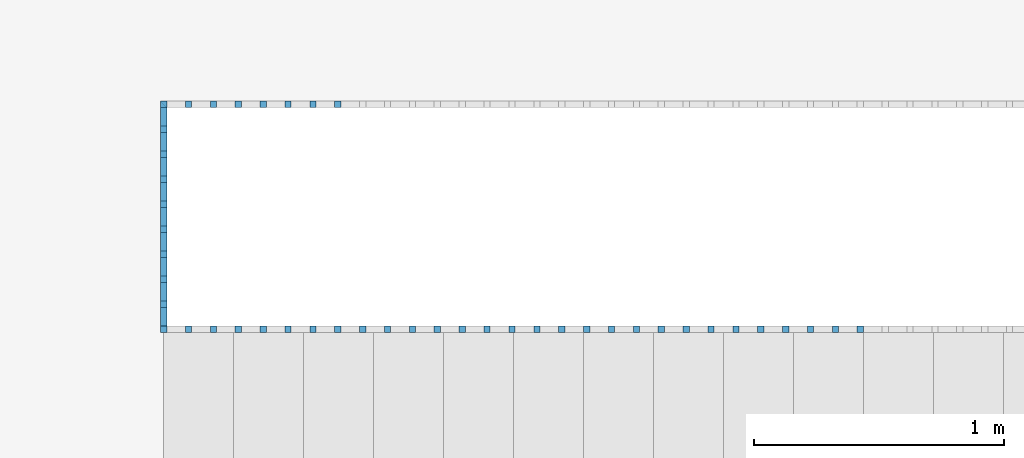
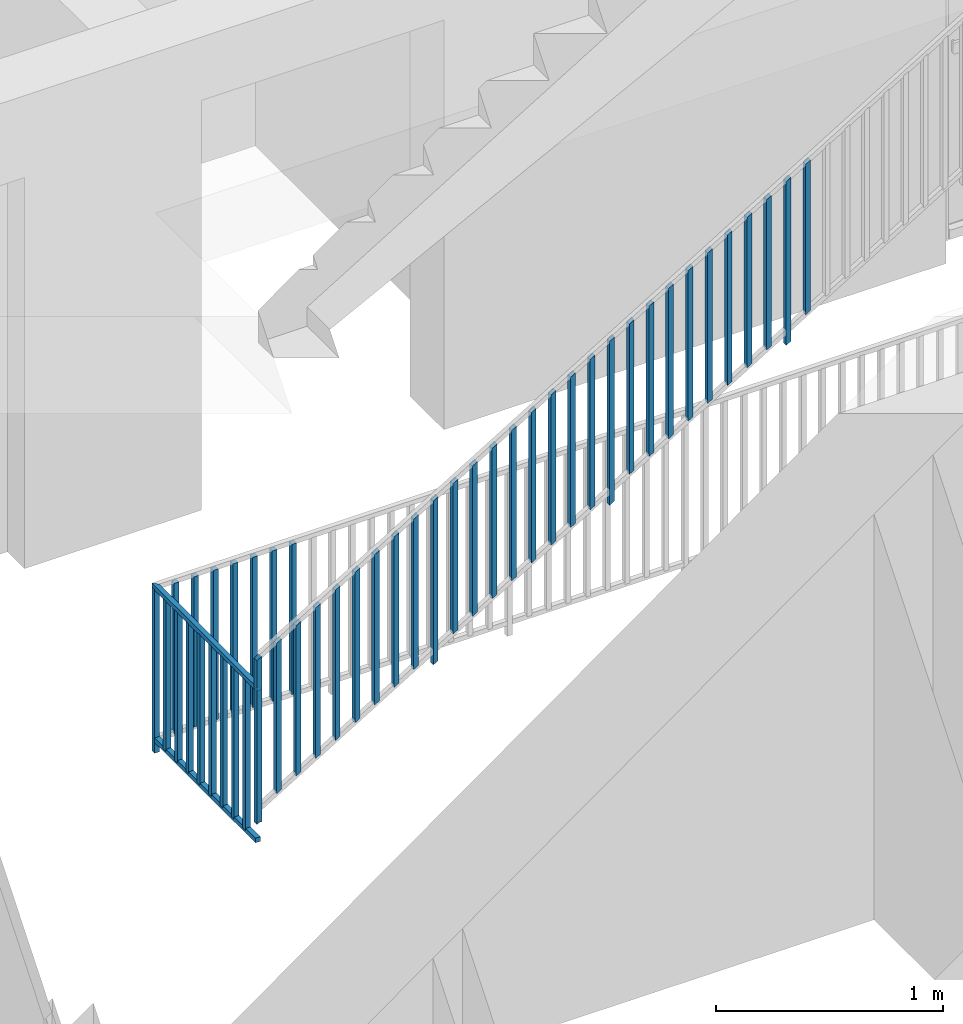
# One storey, part 33 of 48: 48 building element parts, 2 elements without a shape of their own.
"""IFC4 building model written with IfcOpenShell, lengths in metres."""

from ifc_helpers import new_model, entity, si_unit, converted_unit, derived_unit, direction, frame, origin_with_axes, place, context, subcontext, project, spatial, polygons, material, type_object, element, aggregate, save


model = new_model("IFC4")

# Units and contexts
model_context = context("Model", 3, precision=1e-05, world=origin_with_axes(), true_north=direction((0.0, 1.0)))
body_context = subcontext(model_context, "Body", "Model", "MODEL_VIEW")
ifc_project = project(units=[si_unit("LENGTHUNIT", "METRE"), si_unit("AREAUNIT", "SQUARE_METRE"), si_unit("VOLUMEUNIT", "CUBIC_METRE"), converted_unit("PLANEANGLEUNIT", "DEGREE", entity("IfcPlaneAngleMeasure", 0.0174532925199), si_unit("PLANEANGLEUNIT", "RADIAN"), dimensions=[0, 0, 0, 0, 0, 0, 0]), converted_unit("TIMEUNIT", "Year", entity("IfcTimeMeasure", 31556926.0), si_unit("TIMEUNIT", "SECOND"), dimensions=[0, 0, 1, 0, 0, 0, 0]), si_unit("MASSUNIT", "GRAM", prefix="KILO"), si_unit("THERMODYNAMICTEMPERATUREUNIT", "DEGREE_CELSIUS"), si_unit("LUMINOUSINTENSITYUNIT", "LUMEN"), si_unit("ENERGYUNIT", "JOULE", prefix="MEGA"), derived_unit("THERMALCONDUCTANCEUNIT", [(si_unit("POWERUNIT", "WATT"), 1), (si_unit("LENGTHUNIT", "METRE"), -1), (si_unit("THERMODYNAMICTEMPERATUREUNIT", "KELVIN"), -1)]), derived_unit("SPECIFICHEATCAPACITYUNIT", [(si_unit("ENERGYUNIT", "JOULE"), 1), (si_unit("MASSUNIT", "GRAM", prefix="KILO"), -1), (si_unit("THERMODYNAMICTEMPERATUREUNIT", "KELVIN"), -1)]), derived_unit("MASSDENSITYUNIT", [(si_unit("MASSUNIT", "GRAM", prefix="KILO"), 1), (si_unit("VOLUMEUNIT", "CUBIC_METRE"), -1)])], contexts=[model_context])

# Site, building, storey, space
site_placement = place(None, origin_with_axes())
site = spatial("IfcSite", under=ifc_project, at=site_placement, CompositionType="ELEMENT")
building_placement = place(site_placement, origin_with_axes())
building = spatial("IfcBuilding", under=site, at=building_placement, CompositionType="ELEMENT")
storey_placement = place(building_placement, frame((0.0, 0.0, 3.4), z_axis=(0.0, 0.0, 1.0), x_axis=(1.0, 0.0, 0.0)))
storey = spatial("IfcBuildingStorey", under=building, at=storey_placement, Name="1. Geschoss", CompositionType="ELEMENT", Elevation=3.4)
space_placement = place(storey_placement, frame((-3.4421993804, -2.52881223104, 0.0), z_axis=(0.0, 0.0, 1.0), x_axis=(1.0, 0.0, 0.0)))
space = spatial("IfcSpace", under=storey, at=space_placement, CompositionType="ELEMENT", PredefinedType="INTERNAL")

# Railing, building element parts
railing_type = type_object("IfcRailingType", PredefinedType="NOTDEFINED")
railing_1_placement = place(space_placement, frame((0.0, 1.5, 0.17), z_axis=(0.0, 0.0, 1.0), x_axis=(1.0, 0.0, 0.0)))
railing_1 = element("IfcRailing", 1, at=railing_1_placement, inside=space, type_object=railing_type, PredefinedType="NOTDEFINED")
ifc_material = material()
building_element_part_1_placement = place(railing_1_placement, origin_with_axes())
building_element_part_1 = element("IfcBuildingElementPart", 2, at=building_element_part_1_placement, material=ifc_material, PredefinedType="NOTDEFINED", context=body_context, shape_type="Tessellation", body=[
    polygons([(0.0125, -0.0125, 0.00758928571429), (0.0125, 0.0125, 0.00758928571429), (0.0125, 0.0125, 0.887589285714), (0.0125, -0.0125, 0.887589285714), (-0.0125, -0.0125, -0.00758928571429), (-0.0125, 0.0125, -0.00758928571429), (-0.0125, 0.0125, 0.872410714286), (-0.0125, -0.0125, 0.872410714286)], [[[1, 2, 3, 4]], [[1, 5, 6, 2]], [[2, 6, 7, 3]], [[4, 3, 7, 8]], [[5, 1, 4, 8]], [[6, 5, 8, 7]]], closed=True),
])
building_element_part_2_placement = place(railing_1_placement, origin_with_axes())
building_element_part_2 = element("IfcBuildingElementPart", 3, at=building_element_part_2_placement, material=ifc_material, PredefinedType="NOTDEFINED", context=body_context, shape_type="Tessellation", body=[
    polygons([(0.112055555556, -0.0125, 0.138033730159), (0.112055555556, 0.0125, 0.138033730159), (0.112055555556, 0.0125, 0.945533730159), (0.112055555556, -0.0125, 0.945533730159), (0.0870555555556, -0.0125, 0.12285515873), (0.0870555555556, 0.0125, 0.12285515873), (0.0870555555556, 0.0125, 0.93035515873), (0.0870555555556, -0.0125, 0.93035515873)], [[[1, 2, 3, 4]], [[1, 5, 6, 2]], [[2, 6, 7, 3]], [[4, 3, 7, 8]], [[5, 1, 4, 8]], [[6, 5, 8, 7]]], closed=True),
])
building_element_part_3_placement = place(railing_1_placement, origin_with_axes())
building_element_part_3 = element("IfcBuildingElementPart", 4, at=building_element_part_3_placement, material=ifc_material, PredefinedType="NOTDEFINED", context=body_context, shape_type="Tessellation", body=[
    polygons([(0.211611111111, -0.0125, 0.198478174603), (0.211611111111, 0.0125, 0.198478174603), (0.211611111111, 0.0125, 1.0059781746), (0.211611111111, -0.0125, 1.0059781746), (0.186611111111, -0.0125, 0.183299603175), (0.186611111111, 0.0125, 0.183299603175), (0.186611111111, 0.0125, 0.990799603175), (0.186611111111, -0.0125, 0.990799603175)], [[[1, 2, 3, 4]], [[1, 5, 6, 2]], [[2, 6, 7, 3]], [[4, 3, 7, 8]], [[5, 1, 4, 8]], [[6, 5, 8, 7]]], closed=True),
])
building_element_part_4_placement = place(railing_1_placement, origin_with_axes())
building_element_part_4 = element("IfcBuildingElementPart", 5, at=building_element_part_4_placement, material=ifc_material, PredefinedType="NOTDEFINED", context=body_context, shape_type="Tessellation", body=[
    polygons([(0.311166666667, -0.0125, 0.258922619048), (0.311166666667, 0.0125, 0.258922619048), (0.311166666667, 0.0125, 1.06642261905), (0.311166666667, -0.0125, 1.06642261905), (0.286166666667, -0.0125, 0.243744047619), (0.286166666667, 0.0125, 0.243744047619), (0.286166666667, 0.0125, 1.05124404762), (0.286166666667, -0.0125, 1.05124404762)], [[[1, 2, 3, 4]], [[1, 5, 6, 2]], [[2, 6, 7, 3]], [[4, 3, 7, 8]], [[5, 1, 4, 8]], [[6, 5, 8, 7]]], closed=True),
])
building_element_part_5_placement = place(railing_1_placement, origin_with_axes())
building_element_part_5 = element("IfcBuildingElementPart", 6, at=building_element_part_5_placement, material=ifc_material, PredefinedType="NOTDEFINED", context=body_context, shape_type="Tessellation", body=[
    polygons([(0.410722222222, -0.0125, 0.319367063492), (0.410722222222, 0.0125, 0.319367063492), (0.410722222222, 0.0125, 1.12686706349), (0.410722222222, -0.0125, 1.12686706349), (0.385722222222, -0.0125, 0.304188492063), (0.385722222222, 0.0125, 0.304188492063), (0.385722222222, 0.0125, 1.11168849206), (0.385722222222, -0.0125, 1.11168849206)], [[[1, 2, 3, 4]], [[1, 5, 6, 2]], [[2, 6, 7, 3]], [[4, 3, 7, 8]], [[5, 1, 4, 8]], [[6, 5, 8, 7]]], closed=True),
])
building_element_part_6_placement = place(railing_1_placement, origin_with_axes())
building_element_part_6 = element("IfcBuildingElementPart", 7, at=building_element_part_6_placement, material=ifc_material, PredefinedType="NOTDEFINED", context=body_context, shape_type="Tessellation", body=[
    polygons([(0.510277777778, -0.0125, 0.379811507937), (0.510277777778, 0.0125, 0.379811507937), (0.510277777778, 0.0125, 1.18731150794), (0.510277777778, -0.0125, 1.18731150794), (0.485277777778, -0.0125, 0.364632936508), (0.485277777778, 0.0125, 0.364632936508), (0.485277777778, 0.0125, 1.17213293651), (0.485277777778, -0.0125, 1.17213293651)], [[[1, 2, 3, 4]], [[1, 5, 6, 2]], [[2, 6, 7, 3]], [[4, 3, 7, 8]], [[5, 1, 4, 8]], [[6, 5, 8, 7]]], closed=True),
])
building_element_part_7_placement = place(railing_1_placement, origin_with_axes())
building_element_part_7 = element("IfcBuildingElementPart", 8, at=building_element_part_7_placement, material=ifc_material, PredefinedType="NOTDEFINED", context=body_context, shape_type="Tessellation", body=[
    polygons([(0.609833333333, -0.0125, 0.440255952381), (0.609833333333, 0.0125, 0.440255952381), (0.609833333333, 0.0125, 1.24775595238), (0.609833333333, -0.0125, 1.24775595238), (0.584833333333, -0.0125, 0.425077380952), (0.584833333333, 0.0125, 0.425077380952), (0.584833333333, 0.0125, 1.23257738095), (0.584833333333, -0.0125, 1.23257738095)], [[[1, 2, 3, 4]], [[1, 5, 6, 2]], [[2, 6, 7, 3]], [[4, 3, 7, 8]], [[5, 1, 4, 8]], [[6, 5, 8, 7]]], closed=True),
])
building_element_part_8_placement = place(railing_1_placement, origin_with_axes())
building_element_part_8 = element("IfcBuildingElementPart", 9, at=building_element_part_8_placement, material=ifc_material, PredefinedType="NOTDEFINED", context=body_context, shape_type="Tessellation", body=[
    polygons([(0.709388888889, -0.0125, 0.500700396825), (0.709388888889, 0.0125, 0.500700396825), (0.709388888889, 0.0125, 1.30820039683), (0.709388888889, -0.0125, 1.30820039683), (0.684388888889, -0.0125, 0.485521825397), (0.684388888889, 0.0125, 0.485521825397), (0.684388888889, 0.0125, 1.2930218254), (0.684388888889, -0.0125, 1.2930218254)], [[[1, 2, 3, 4]], [[1, 5, 6, 2]], [[2, 6, 7, 3]], [[4, 3, 7, 8]], [[5, 1, 4, 8]], [[6, 5, 8, 7]]], closed=True),
])
building_element_part_9_placement = place(railing_1_placement, origin_with_axes())
building_element_part_9 = element("IfcBuildingElementPart", 10, at=building_element_part_9_placement, material=ifc_material, PredefinedType="NOTDEFINED", context=body_context, shape_type="Tessellation", body=[
    polygons([(0.808944444444, -0.0125, 0.56114484127), (0.808944444444, 0.0125, 0.56114484127), (0.808944444444, 0.0125, 1.36864484127), (0.808944444444, -0.0125, 1.36864484127), (0.783944444444, -0.0125, 0.545966269841), (0.783944444444, 0.0125, 0.545966269841), (0.783944444444, 0.0125, 1.35346626984), (0.783944444444, -0.0125, 1.35346626984)], [[[1, 2, 3, 4]], [[1, 5, 6, 2]], [[2, 6, 7, 3]], [[4, 3, 7, 8]], [[5, 1, 4, 8]], [[6, 5, 8, 7]]], closed=True),
])
building_element_part_10_placement = place(railing_1_placement, origin_with_axes())
building_element_part_10 = element("IfcBuildingElementPart", 11, at=building_element_part_10_placement, material=ifc_material, PredefinedType="NOTDEFINED", context=body_context, shape_type="Tessellation", body=[
    polygons([(0.9085, -0.0125, 0.551589285714), (0.9085, 0.0125, 0.551589285714), (0.9085, 0.0125, 1.43158928571), (0.9085, -0.0125, 1.43158928571), (0.8835, -0.0125, 0.536410714286), (0.8835, 0.0125, 0.536410714286), (0.8835, 0.0125, 1.41641071429), (0.8835, -0.0125, 1.41641071429)], [[[1, 2, 3, 4]], [[1, 5, 6, 2]], [[2, 6, 7, 3]], [[4, 3, 7, 8]], [[5, 1, 4, 8]], [[6, 5, 8, 7]]], closed=True),
])
building_element_part_11_placement = place(railing_1_placement, origin_with_axes())
building_element_part_11 = element("IfcBuildingElementPart", 12, at=building_element_part_11_placement, material=ifc_material, PredefinedType="NOTDEFINED", context=body_context, shape_type="Tessellation", body=[
    polygons([(1.00805555556, -0.0125, 0.682033730159), (1.00805555556, 0.0125, 0.682033730159), (1.00805555556, 0.0125, 1.48953373016), (1.00805555556, -0.0125, 1.48953373016), (0.983055555556, -0.0125, 0.66685515873), (0.983055555556, 0.0125, 0.66685515873), (0.983055555556, 0.0125, 1.47435515873), (0.983055555556, -0.0125, 1.47435515873)], [[[1, 2, 3, 4]], [[1, 5, 6, 2]], [[2, 6, 7, 3]], [[4, 3, 7, 8]], [[5, 1, 4, 8]], [[6, 5, 8, 7]]], closed=True),
])
building_element_part_12_placement = place(railing_1_placement, origin_with_axes())
building_element_part_12 = element("IfcBuildingElementPart", 13, at=building_element_part_12_placement, material=ifc_material, PredefinedType="NOTDEFINED", context=body_context, shape_type="Tessellation", body=[
    polygons([(1.10761111111, -0.0125, 0.742478174603), (1.10761111111, 0.0125, 0.742478174603), (1.10761111111, 0.0125, 1.5499781746), (1.10761111111, -0.0125, 1.5499781746), (1.08261111111, -0.0125, 0.727299603175), (1.08261111111, 0.0125, 0.727299603175), (1.08261111111, 0.0125, 1.53479960317), (1.08261111111, -0.0125, 1.53479960317)], [[[1, 2, 3, 4]], [[1, 5, 6, 2]], [[2, 6, 7, 3]], [[4, 3, 7, 8]], [[5, 1, 4, 8]], [[6, 5, 8, 7]]], closed=True),
])
building_element_part_13_placement = place(railing_1_placement, origin_with_axes())
building_element_part_13 = element("IfcBuildingElementPart", 14, at=building_element_part_13_placement, material=ifc_material, PredefinedType="NOTDEFINED", context=body_context, shape_type="Tessellation", body=[
    polygons([(1.20716666667, -0.0125, 0.802922619048), (1.20716666667, 0.0125, 0.802922619048), (1.20716666667, 0.0125, 1.61042261905), (1.20716666667, -0.0125, 1.61042261905), (1.18216666667, -0.0125, 0.787744047619), (1.18216666667, 0.0125, 0.787744047619), (1.18216666667, 0.0125, 1.59524404762), (1.18216666667, -0.0125, 1.59524404762)], [[[1, 2, 3, 4]], [[1, 5, 6, 2]], [[2, 6, 7, 3]], [[4, 3, 7, 8]], [[5, 1, 4, 8]], [[6, 5, 8, 7]]], closed=True),
])
building_element_part_14_placement = place(railing_1_placement, origin_with_axes())
building_element_part_14 = element("IfcBuildingElementPart", 15, at=building_element_part_14_placement, material=ifc_material, PredefinedType="NOTDEFINED", context=body_context, shape_type="Tessellation", body=[
    polygons([(1.30672222222, -0.0125, 0.863367063492), (1.30672222222, 0.0125, 0.863367063492), (1.30672222222, 0.0125, 1.67086706349), (1.30672222222, -0.0125, 1.67086706349), (1.28172222222, -0.0125, 0.848188492063), (1.28172222222, 0.0125, 0.848188492063), (1.28172222222, 0.0125, 1.65568849206), (1.28172222222, -0.0125, 1.65568849206)], [[[1, 2, 3, 4]], [[1, 5, 6, 2]], [[2, 6, 7, 3]], [[4, 3, 7, 8]], [[5, 1, 4, 8]], [[6, 5, 8, 7]]], closed=True),
])
building_element_part_15_placement = place(railing_1_placement, origin_with_axes())
building_element_part_15 = element("IfcBuildingElementPart", 16, at=building_element_part_15_placement, material=ifc_material, PredefinedType="NOTDEFINED", context=body_context, shape_type="Tessellation", body=[
    polygons([(1.40627777778, -0.0125, 0.923811507937), (1.40627777778, 0.0125, 0.923811507937), (1.40627777778, 0.0125, 1.73131150794), (1.40627777778, -0.0125, 1.73131150794), (1.38127777778, -0.0125, 0.908632936508), (1.38127777778, 0.0125, 0.908632936508), (1.38127777778, 0.0125, 1.71613293651), (1.38127777778, -0.0125, 1.71613293651)], [[[1, 2, 3, 4]], [[1, 5, 6, 2]], [[2, 6, 7, 3]], [[4, 3, 7, 8]], [[5, 1, 4, 8]], [[6, 5, 8, 7]]], closed=True),
])
building_element_part_16_placement = place(railing_1_placement, origin_with_axes())
building_element_part_16 = element("IfcBuildingElementPart", 17, at=building_element_part_16_placement, material=ifc_material, PredefinedType="NOTDEFINED", context=body_context, shape_type="Tessellation", body=[
    polygons([(1.50583333333, -0.0125, 0.984255952381), (1.50583333333, 0.0125, 0.984255952381), (1.50583333333, 0.0125, 1.79175595238), (1.50583333333, -0.0125, 1.79175595238), (1.48083333333, -0.0125, 0.969077380952), (1.48083333333, 0.0125, 0.969077380952), (1.48083333333, 0.0125, 1.77657738095), (1.48083333333, -0.0125, 1.77657738095)], [[[1, 2, 3, 4]], [[1, 5, 6, 2]], [[2, 6, 7, 3]], [[4, 3, 7, 8]], [[5, 1, 4, 8]], [[6, 5, 8, 7]]], closed=True),
])
building_element_part_17_placement = place(railing_1_placement, origin_with_axes())
building_element_part_17 = element("IfcBuildingElementPart", 18, at=building_element_part_17_placement, material=ifc_material, PredefinedType="NOTDEFINED", context=body_context, shape_type="Tessellation", body=[
    polygons([(1.60538888889, -0.0125, 1.04470039683), (1.60538888889, 0.0125, 1.04470039683), (1.60538888889, 0.0125, 1.85220039683), (1.60538888889, -0.0125, 1.85220039683), (1.58038888889, -0.0125, 1.0295218254), (1.58038888889, 0.0125, 1.0295218254), (1.58038888889, 0.0125, 1.8370218254), (1.58038888889, -0.0125, 1.8370218254)], [[[1, 2, 3, 4]], [[1, 5, 6, 2]], [[2, 6, 7, 3]], [[4, 3, 7, 8]], [[5, 1, 4, 8]], [[6, 5, 8, 7]]], closed=True),
])
building_element_part_18_placement = place(railing_1_placement, origin_with_axes())
building_element_part_18 = element("IfcBuildingElementPart", 19, at=building_element_part_18_placement, material=ifc_material, PredefinedType="NOTDEFINED", context=body_context, shape_type="Tessellation", body=[
    polygons([(1.70494444444, -0.0125, 1.10514484127), (1.70494444444, 0.0125, 1.10514484127), (1.70494444444, 0.0125, 1.91264484127), (1.70494444444, -0.0125, 1.91264484127), (1.67994444444, -0.0125, 1.08996626984), (1.67994444444, 0.0125, 1.08996626984), (1.67994444444, 0.0125, 1.89746626984), (1.67994444444, -0.0125, 1.89746626984)], [[[1, 2, 3, 4]], [[1, 5, 6, 2]], [[2, 6, 7, 3]], [[4, 3, 7, 8]], [[5, 1, 4, 8]], [[6, 5, 8, 7]]], closed=True),
])
building_element_part_19_placement = place(railing_1_placement, origin_with_axes())
building_element_part_19 = element("IfcBuildingElementPart", 20, at=building_element_part_19_placement, material=ifc_material, PredefinedType="NOTDEFINED", context=body_context, shape_type="Tessellation", body=[
    polygons([(1.8045, -0.0125, 1.09558928571), (1.8045, 0.0125, 1.09558928571), (1.8045, 0.0125, 1.97558928571), (1.8045, -0.0125, 1.97558928571), (1.7795, -0.0125, 1.08041071429), (1.7795, 0.0125, 1.08041071429), (1.7795, 0.0125, 1.96041071429), (1.7795, -0.0125, 1.96041071429)], [[[1, 2, 3, 4]], [[1, 5, 6, 2]], [[2, 6, 7, 3]], [[4, 3, 7, 8]], [[5, 1, 4, 8]], [[6, 5, 8, 7]]], closed=True),
])
building_element_part_20_placement = place(railing_1_placement, origin_with_axes())
building_element_part_20 = element("IfcBuildingElementPart", 21, at=building_element_part_20_placement, material=ifc_material, PredefinedType="NOTDEFINED", context=body_context, shape_type="Tessellation", body=[
    polygons([(1.90405555556, -0.0125, 1.22603373016), (1.90405555556, 0.0125, 1.22603373016), (1.90405555556, 0.0125, 2.03353373016), (1.90405555556, -0.0125, 2.03353373016), (1.87905555556, -0.0125, 1.21085515873), (1.87905555556, 0.0125, 1.21085515873), (1.87905555556, 0.0125, 2.01835515873), (1.87905555556, -0.0125, 2.01835515873)], [[[1, 2, 3, 4]], [[1, 5, 6, 2]], [[2, 6, 7, 3]], [[4, 3, 7, 8]], [[5, 1, 4, 8]], [[6, 5, 8, 7]]], closed=True),
])
building_element_part_21_placement = place(railing_1_placement, origin_with_axes())
building_element_part_21 = element("IfcBuildingElementPart", 22, at=building_element_part_21_placement, material=ifc_material, PredefinedType="NOTDEFINED", context=body_context, shape_type="Tessellation", body=[
    polygons([(2.00361111111, -0.0125, 1.2864781746), (2.00361111111, 0.0125, 1.2864781746), (2.00361111111, 0.0125, 2.0939781746), (2.00361111111, -0.0125, 2.0939781746), (1.97861111111, -0.0125, 1.27129960317), (1.97861111111, 0.0125, 1.27129960317), (1.97861111111, 0.0125, 2.07879960317), (1.97861111111, -0.0125, 2.07879960317)], [[[1, 2, 3, 4]], [[1, 5, 6, 2]], [[2, 6, 7, 3]], [[4, 3, 7, 8]], [[5, 1, 4, 8]], [[6, 5, 8, 7]]], closed=True),
])
building_element_part_22_placement = place(railing_1_placement, origin_with_axes())
building_element_part_22 = element("IfcBuildingElementPart", 23, at=building_element_part_22_placement, material=ifc_material, PredefinedType="NOTDEFINED", context=body_context, shape_type="Tessellation", body=[
    polygons([(2.10316666667, -0.0125, 1.34692261905), (2.10316666667, 0.0125, 1.34692261905), (2.10316666667, 0.0125, 2.15442261905), (2.10316666667, -0.0125, 2.15442261905), (2.07816666667, -0.0125, 1.33174404762), (2.07816666667, 0.0125, 1.33174404762), (2.07816666667, 0.0125, 2.13924404762), (2.07816666667, -0.0125, 2.13924404762)], [[[1, 2, 3, 4]], [[1, 5, 6, 2]], [[2, 6, 7, 3]], [[4, 3, 7, 8]], [[5, 1, 4, 8]], [[6, 5, 8, 7]]], closed=True),
])
building_element_part_23_placement = place(railing_1_placement, origin_with_axes())
building_element_part_23 = element("IfcBuildingElementPart", 24, at=building_element_part_23_placement, material=ifc_material, PredefinedType="NOTDEFINED", context=body_context, shape_type="Tessellation", body=[
    polygons([(2.20272222222, -0.0125, 1.40736706349), (2.20272222222, 0.0125, 1.40736706349), (2.20272222222, 0.0125, 2.21486706349), (2.20272222222, -0.0125, 2.21486706349), (2.17772222222, -0.0125, 1.39218849206), (2.17772222222, 0.0125, 1.39218849206), (2.17772222222, 0.0125, 2.19968849206), (2.17772222222, -0.0125, 2.19968849206)], [[[1, 2, 3, 4]], [[1, 5, 6, 2]], [[2, 6, 7, 3]], [[4, 3, 7, 8]], [[5, 1, 4, 8]], [[6, 5, 8, 7]]], closed=True),
])
building_element_part_24_placement = place(railing_1_placement, origin_with_axes())
building_element_part_24 = element("IfcBuildingElementPart", 25, at=building_element_part_24_placement, material=ifc_material, PredefinedType="NOTDEFINED", context=body_context, shape_type="Tessellation", body=[
    polygons([(2.30227777778, -0.0125, 1.46781150794), (2.30227777778, 0.0125, 1.46781150794), (2.30227777778, 0.0125, 2.27531150794), (2.30227777778, -0.0125, 2.27531150794), (2.27727777778, -0.0125, 1.45263293651), (2.27727777778, 0.0125, 1.45263293651), (2.27727777778, 0.0125, 2.26013293651), (2.27727777778, -0.0125, 2.26013293651)], [[[1, 2, 3, 4]], [[1, 5, 6, 2]], [[2, 6, 7, 3]], [[4, 3, 7, 8]], [[5, 1, 4, 8]], [[6, 5, 8, 7]]], closed=True),
])
building_element_part_25_placement = place(railing_1_placement, origin_with_axes())
building_element_part_25 = element("IfcBuildingElementPart", 26, at=building_element_part_25_placement, material=ifc_material, PredefinedType="NOTDEFINED", context=body_context, shape_type="Tessellation", body=[
    polygons([(2.40183333333, -0.0125, 1.52825595238), (2.40183333333, 0.0125, 1.52825595238), (2.40183333333, 0.0125, 2.33575595238), (2.40183333333, -0.0125, 2.33575595238), (2.37683333333, -0.0125, 1.51307738095), (2.37683333333, 0.0125, 1.51307738095), (2.37683333333, 0.0125, 2.32057738095), (2.37683333333, -0.0125, 2.32057738095)], [[[1, 2, 3, 4]], [[1, 5, 6, 2]], [[2, 6, 7, 3]], [[4, 3, 7, 8]], [[5, 1, 4, 8]], [[6, 5, 8, 7]]], closed=True),
])
building_element_part_26_placement = place(railing_1_placement, origin_with_axes())
building_element_part_26 = element("IfcBuildingElementPart", 27, at=building_element_part_26_placement, material=ifc_material, PredefinedType="NOTDEFINED", context=body_context, shape_type="Tessellation", body=[
    polygons([(2.50138888889, -0.0125, 1.58870039683), (2.50138888889, 0.0125, 1.58870039683), (2.50138888889, 0.0125, 2.39620039683), (2.50138888889, -0.0125, 2.39620039683), (2.47638888889, -0.0125, 1.5735218254), (2.47638888889, 0.0125, 1.5735218254), (2.47638888889, 0.0125, 2.3810218254), (2.47638888889, -0.0125, 2.3810218254)], [[[1, 2, 3, 4]], [[1, 5, 6, 2]], [[2, 6, 7, 3]], [[4, 3, 7, 8]], [[5, 1, 4, 8]], [[6, 5, 8, 7]]], closed=True),
])
building_element_part_27_placement = place(railing_1_placement, origin_with_axes())
building_element_part_27 = element("IfcBuildingElementPart", 28, at=building_element_part_27_placement, material=ifc_material, PredefinedType="NOTDEFINED", context=body_context, shape_type="Tessellation", body=[
    polygons([(2.60094444444, -0.0125, 1.64914484127), (2.60094444444, 0.0125, 1.64914484127), (2.60094444444, 0.0125, 2.45664484127), (2.60094444444, -0.0125, 2.45664484127), (2.57594444444, -0.0125, 1.63396626984), (2.57594444444, 0.0125, 1.63396626984), (2.57594444444, 0.0125, 2.44146626984), (2.57594444444, -0.0125, 2.44146626984)], [[[1, 2, 3, 4]], [[1, 5, 6, 2]], [[2, 6, 7, 3]], [[4, 3, 7, 8]], [[5, 1, 4, 8]], [[6, 5, 8, 7]]], closed=True),
])
building_element_part_28_placement = place(railing_1_placement, origin_with_axes())
building_element_part_28 = element("IfcBuildingElementPart", 29, at=building_element_part_28_placement, material=ifc_material, PredefinedType="NOTDEFINED", context=body_context, shape_type="Tessellation", body=[
    polygons([(2.7005, -0.0125, 1.63958928571), (2.7005, 0.0125, 1.63958928571), (2.7005, 0.0125, 2.51958928571), (2.7005, -0.0125, 2.51958928571), (2.6755, -0.0125, 1.62441071429), (2.6755, 0.0125, 1.62441071429), (2.6755, 0.0125, 2.50441071429), (2.6755, -0.0125, 2.50441071429)], [[[1, 2, 3, 4]], [[1, 5, 6, 2]], [[2, 6, 7, 3]], [[4, 3, 7, 8]], [[5, 1, 4, 8]], [[6, 5, 8, 7]]], closed=True),
])
building_element_part_29_placement = place(railing_1_placement, origin_with_axes())
building_element_part_29 = element("IfcBuildingElementPart", 30, at=building_element_part_29_placement, material=ifc_material, PredefinedType="NOTDEFINED", context=body_context, shape_type="Tessellation", body=[
    polygons([(2.80005555556, -0.0125, 1.77003373016), (2.80005555556, 0.0125, 1.77003373016), (2.80005555556, 0.0125, 2.57753373016), (2.80005555556, -0.0125, 2.57753373016), (2.77505555556, -0.0125, 1.75485515873), (2.77505555556, 0.0125, 1.75485515873), (2.77505555556, 0.0125, 2.56235515873), (2.77505555556, -0.0125, 2.56235515873)], [[[1, 2, 3, 4]], [[1, 5, 6, 2]], [[2, 6, 7, 3]], [[4, 3, 7, 8]], [[5, 1, 4, 8]], [[6, 5, 8, 7]]], closed=True),
])
aggregate(railing_1, [building_element_part_1, building_element_part_2, building_element_part_3, building_element_part_4, building_element_part_5, building_element_part_6, building_element_part_7, building_element_part_8, building_element_part_9, building_element_part_10, building_element_part_11, building_element_part_12, building_element_part_13, building_element_part_14, building_element_part_15, building_element_part_16, building_element_part_17, building_element_part_18, building_element_part_19, building_element_part_20, building_element_part_21, building_element_part_22, building_element_part_23, building_element_part_24, building_element_part_25, building_element_part_26, building_element_part_27, building_element_part_28, building_element_part_29])

railing_2_placement = place(space_placement, frame((0.0, 1.5, 0.0), z_axis=(0.0, 0.0, 1.0), x_axis=(1.0, 0.0, 0.0)))
railing_2 = element("IfcRailing", 31, at=railing_2_placement, inside=space, type_object=railing_type, PredefinedType="NOTDEFINED")
building_element_part_30_placement = place(railing_2_placement, origin_with_axes())
building_element_part_30 = element("IfcBuildingElementPart", 32, at=building_element_part_30_placement, material=ifc_material, PredefinedType="NOTDEFINED", context=body_context, shape_type="Tessellation", body=[
    polygons([(0.0125, 0.0125, 0.17), (-0.0125, 0.0125, 0.17), (-0.0125, 0.0125, 0.88), (0.0125, 0.0125, 0.88), (0.0125, -0.0125, 0.17), (-0.0125, -0.0125, 0.17), (-0.0125, -0.0125, 0.88), (0.0125, -0.0125, 0.88)], [[[1, 2, 3, 4]], [[1, 5, 6, 2]], [[2, 6, 7, 3]], [[4, 3, 7, 8]], [[5, 1, 4, 8]], [[6, 5, 8, 7]]], closed=True),
])
building_element_part_31_placement = place(railing_2_placement, origin_with_axes())
building_element_part_31 = element("IfcBuildingElementPart", 33, at=building_element_part_31_placement, material=ifc_material, PredefinedType="NOTDEFINED", context=body_context, shape_type="Tessellation", body=[
    polygons([(0.0125, 0.9125, 0.0), (-0.0125, 0.9125, 0.0), (-0.0125, 0.9125, 0.88), (0.0125, 0.9125, 0.88), (0.0125, 0.8875, 0.0), (-0.0125, 0.8875, 0.0), (-0.0125, 0.8875, 0.88), (0.0125, 0.8875, 0.88)], [[[1, 2, 3, 4]], [[1, 5, 6, 2]], [[2, 6, 7, 3]], [[4, 3, 7, 8]], [[5, 1, 4, 8]], [[6, 5, 8, 7]]], closed=True),
])
building_element_part_32_placement = place(railing_2_placement, origin_with_axes())
building_element_part_32 = element("IfcBuildingElementPart", 34, at=building_element_part_32_placement, material=ifc_material, PredefinedType="NOTDEFINED", context=body_context, shape_type="Tessellation", body=[
    polygons([(0.0125, 0.0, 0.9), (0.0125, 0.0, 0.875), (0.0125, 0.8875, 0.875), (0.0125, 0.8875, 0.9), (-0.0125, 0.0, 0.9), (-0.0125, 0.0, 0.875), (-0.0125, 0.9125, 0.875), (-0.0125, 0.9125, 0.9)], [[[1, 2, 3, 4]], [[1, 5, 6, 2]], [[2, 6, 7, 3]], [[4, 3, 7, 8]], [[5, 1, 4, 8]], [[6, 5, 8, 7]]], closed=True),
])
building_element_part_33_placement = place(railing_2_placement, origin_with_axes())
building_element_part_33 = element("IfcBuildingElementPart", 35, at=building_element_part_33_placement, material=ifc_material, PredefinedType="NOTDEFINED", context=body_context, shape_type="Tessellation", body=[
    polygons([(0.0125, 0.0, 0.0825), (0.0125, 0.0, 0.0575), (0.0125, 0.8875, 0.0575), (0.0125, 0.8875, 0.0825), (-0.0125, 0.0, 0.0825), (-0.0125, 0.0, 0.0575), (-0.0125, 0.9125, 0.0575), (-0.0125, 0.9125, 0.0825)], [[[1, 2, 3, 4]], [[1, 5, 6, 2]], [[2, 6, 7, 3]], [[4, 3, 7, 8]], [[5, 1, 4, 8]], [[6, 5, 8, 7]]], closed=True),
])
building_element_part_34_placement = place(railing_2_placement, origin_with_axes())
building_element_part_34 = element("IfcBuildingElementPart", 36, at=building_element_part_34_placement, material=ifc_material, PredefinedType="NOTDEFINED", context=body_context, shape_type="Tessellation", body=[
    polygons([(0.0125, 0.1125, 0.07), (-0.0125, 0.1125, 0.07), (-0.0125, 0.1125, 0.8775), (0.0125, 0.1125, 0.8775), (0.0125, 0.0875, 0.07), (-0.0125, 0.0875, 0.07), (-0.0125, 0.0875, 0.8775), (0.0125, 0.0875, 0.8775)], [[[1, 2, 3, 4]], [[1, 5, 6, 2]], [[2, 6, 7, 3]], [[4, 3, 7, 8]], [[5, 1, 4, 8]], [[6, 5, 8, 7]]], closed=True),
])
building_element_part_35_placement = place(railing_2_placement, origin_with_axes())
building_element_part_35 = element("IfcBuildingElementPart", 37, at=building_element_part_35_placement, material=ifc_material, PredefinedType="NOTDEFINED", context=body_context, shape_type="Tessellation", body=[
    polygons([(0.0125, 0.2125, 0.07), (-0.0125, 0.2125, 0.07), (-0.0125, 0.2125, 0.8775), (0.0125, 0.2125, 0.8775), (0.0125, 0.1875, 0.07), (-0.0125, 0.1875, 0.07), (-0.0125, 0.1875, 0.8775), (0.0125, 0.1875, 0.8775)], [[[1, 2, 3, 4]], [[1, 5, 6, 2]], [[2, 6, 7, 3]], [[4, 3, 7, 8]], [[5, 1, 4, 8]], [[6, 5, 8, 7]]], closed=True),
])
building_element_part_36_placement = place(railing_2_placement, origin_with_axes())
building_element_part_36 = element("IfcBuildingElementPart", 38, at=building_element_part_36_placement, material=ifc_material, PredefinedType="NOTDEFINED", context=body_context, shape_type="Tessellation", body=[
    polygons([(0.0125, 0.3125, 0.07), (-0.0125, 0.3125, 0.07), (-0.0125, 0.3125, 0.8775), (0.0125, 0.3125, 0.8775), (0.0125, 0.2875, 0.07), (-0.0125, 0.2875, 0.07), (-0.0125, 0.2875, 0.8775), (0.0125, 0.2875, 0.8775)], [[[1, 2, 3, 4]], [[1, 5, 6, 2]], [[2, 6, 7, 3]], [[4, 3, 7, 8]], [[5, 1, 4, 8]], [[6, 5, 8, 7]]], closed=True),
])
building_element_part_37_placement = place(railing_2_placement, origin_with_axes())
building_element_part_37 = element("IfcBuildingElementPart", 39, at=building_element_part_37_placement, material=ifc_material, PredefinedType="NOTDEFINED", context=body_context, shape_type="Tessellation", body=[
    polygons([(0.0125, 0.4125, 0.07), (-0.0125, 0.4125, 0.07), (-0.0125, 0.4125, 0.8775), (0.0125, 0.4125, 0.8775), (0.0125, 0.3875, 0.07), (-0.0125, 0.3875, 0.07), (-0.0125, 0.3875, 0.8775), (0.0125, 0.3875, 0.8775)], [[[1, 2, 3, 4]], [[1, 5, 6, 2]], [[2, 6, 7, 3]], [[4, 3, 7, 8]], [[5, 1, 4, 8]], [[6, 5, 8, 7]]], closed=True),
])
building_element_part_38_placement = place(railing_2_placement, origin_with_axes())
building_element_part_38 = element("IfcBuildingElementPart", 40, at=building_element_part_38_placement, material=ifc_material, PredefinedType="NOTDEFINED", context=body_context, shape_type="Tessellation", body=[
    polygons([(0.0125, 0.5125, 0.07), (-0.0125, 0.5125, 0.07), (-0.0125, 0.5125, 0.8775), (0.0125, 0.5125, 0.8775), (0.0125, 0.4875, 0.07), (-0.0125, 0.4875, 0.07), (-0.0125, 0.4875, 0.8775), (0.0125, 0.4875, 0.8775)], [[[1, 2, 3, 4]], [[1, 5, 6, 2]], [[2, 6, 7, 3]], [[4, 3, 7, 8]], [[5, 1, 4, 8]], [[6, 5, 8, 7]]], closed=True),
])
building_element_part_39_placement = place(railing_2_placement, origin_with_axes())
building_element_part_39 = element("IfcBuildingElementPart", 41, at=building_element_part_39_placement, material=ifc_material, PredefinedType="NOTDEFINED", context=body_context, shape_type="Tessellation", body=[
    polygons([(0.0125, 0.6125, 0.07), (-0.0125, 0.6125, 0.07), (-0.0125, 0.6125, 0.8775), (0.0125, 0.6125, 0.8775), (0.0125, 0.5875, 0.07), (-0.0125, 0.5875, 0.07), (-0.0125, 0.5875, 0.8775), (0.0125, 0.5875, 0.8775)], [[[1, 2, 3, 4]], [[1, 5, 6, 2]], [[2, 6, 7, 3]], [[4, 3, 7, 8]], [[5, 1, 4, 8]], [[6, 5, 8, 7]]], closed=True),
])
building_element_part_40_placement = place(railing_2_placement, origin_with_axes())
building_element_part_40 = element("IfcBuildingElementPart", 42, at=building_element_part_40_placement, material=ifc_material, PredefinedType="NOTDEFINED", context=body_context, shape_type="Tessellation", body=[
    polygons([(0.0125, 0.7125, 0.07), (-0.0125, 0.7125, 0.07), (-0.0125, 0.7125, 0.8775), (0.0125, 0.7125, 0.8775), (0.0125, 0.6875, 0.07), (-0.0125, 0.6875, 0.07), (-0.0125, 0.6875, 0.8775), (0.0125, 0.6875, 0.8775)], [[[1, 2, 3, 4]], [[1, 5, 6, 2]], [[2, 6, 7, 3]], [[4, 3, 7, 8]], [[5, 1, 4, 8]], [[6, 5, 8, 7]]], closed=True),
])
building_element_part_41_placement = place(railing_2_placement, origin_with_axes())
building_element_part_41 = element("IfcBuildingElementPart", 43, at=building_element_part_41_placement, material=ifc_material, PredefinedType="NOTDEFINED", context=body_context, shape_type="Tessellation", body=[
    polygons([(0.0125, 0.8125, 0.07), (-0.0125, 0.8125, 0.07), (-0.0125, 0.8125, 0.8775), (0.0125, 0.8125, 0.8775), (0.0125, 0.7875, 0.07), (-0.0125, 0.7875, 0.07), (-0.0125, 0.7875, 0.8775), (0.0125, 0.7875, 0.8775)], [[[1, 2, 3, 4]], [[1, 5, 6, 2]], [[2, 6, 7, 3]], [[4, 3, 7, 8]], [[5, 1, 4, 8]], [[6, 5, 8, 7]]], closed=True),
])
building_element_part_42_placement = place(railing_2_placement, origin_with_axes())
building_element_part_42 = element("IfcBuildingElementPart", 44, at=building_element_part_42_placement, material=ifc_material, PredefinedType="NOTDEFINED", context=body_context, shape_type="Tessellation", body=[
    polygons([(0.112055555556, 0.8875, 0.07), (0.112055555556, 0.9125, 0.07), (0.112055555556, 0.9125, 0.8775), (0.112055555556, 0.8875, 0.8775), (0.0870555555556, 0.8875, 0.07), (0.0870555555556, 0.9125, 0.07), (0.0870555555556, 0.9125, 0.8775), (0.0870555555556, 0.8875, 0.8775)], [[[1, 2, 3, 4]], [[1, 5, 6, 2]], [[2, 6, 7, 3]], [[4, 3, 7, 8]], [[5, 1, 4, 8]], [[6, 5, 8, 7]]], closed=True),
])
building_element_part_43_placement = place(railing_2_placement, origin_with_axes())
building_element_part_43 = element("IfcBuildingElementPart", 45, at=building_element_part_43_placement, material=ifc_material, PredefinedType="NOTDEFINED", context=body_context, shape_type="Tessellation", body=[
    polygons([(0.211611111111, 0.8875, 0.07), (0.211611111111, 0.9125, 0.07), (0.211611111111, 0.9125, 0.8775), (0.211611111111, 0.8875, 0.8775), (0.186611111111, 0.8875, 0.07), (0.186611111111, 0.9125, 0.07), (0.186611111111, 0.9125, 0.8775), (0.186611111111, 0.8875, 0.8775)], [[[1, 2, 3, 4]], [[1, 5, 6, 2]], [[2, 6, 7, 3]], [[4, 3, 7, 8]], [[5, 1, 4, 8]], [[6, 5, 8, 7]]], closed=True),
])
building_element_part_44_placement = place(railing_2_placement, origin_with_axes())
building_element_part_44 = element("IfcBuildingElementPart", 46, at=building_element_part_44_placement, material=ifc_material, PredefinedType="NOTDEFINED", context=body_context, shape_type="Tessellation", body=[
    polygons([(0.311166666667, 0.8875, 0.07), (0.311166666667, 0.9125, 0.07), (0.311166666667, 0.9125, 0.8775), (0.311166666667, 0.8875, 0.8775), (0.286166666667, 0.8875, 0.07), (0.286166666667, 0.9125, 0.07), (0.286166666667, 0.9125, 0.8775), (0.286166666667, 0.8875, 0.8775)], [[[1, 2, 3, 4]], [[1, 5, 6, 2]], [[2, 6, 7, 3]], [[4, 3, 7, 8]], [[5, 1, 4, 8]], [[6, 5, 8, 7]]], closed=True),
])
building_element_part_45_placement = place(railing_2_placement, origin_with_axes())
building_element_part_45 = element("IfcBuildingElementPart", 47, at=building_element_part_45_placement, material=ifc_material, PredefinedType="NOTDEFINED", context=body_context, shape_type="Tessellation", body=[
    polygons([(0.410722222222, 0.8875, 0.07), (0.410722222222, 0.9125, 0.07), (0.410722222222, 0.9125, 0.8775), (0.410722222222, 0.8875, 0.8775), (0.385722222222, 0.8875, 0.07), (0.385722222222, 0.9125, 0.07), (0.385722222222, 0.9125, 0.8775), (0.385722222222, 0.8875, 0.8775)], [[[1, 2, 3, 4]], [[1, 5, 6, 2]], [[2, 6, 7, 3]], [[4, 3, 7, 8]], [[5, 1, 4, 8]], [[6, 5, 8, 7]]], closed=True),
])
building_element_part_46_placement = place(railing_2_placement, origin_with_axes())
building_element_part_46 = element("IfcBuildingElementPart", 48, at=building_element_part_46_placement, material=ifc_material, PredefinedType="NOTDEFINED", context=body_context, shape_type="Tessellation", body=[
    polygons([(0.510277777778, 0.8875, 0.07), (0.510277777778, 0.9125, 0.07), (0.510277777778, 0.9125, 0.8775), (0.510277777778, 0.8875, 0.8775), (0.485277777778, 0.8875, 0.07), (0.485277777778, 0.9125, 0.07), (0.485277777778, 0.9125, 0.8775), (0.485277777778, 0.8875, 0.8775)], [[[1, 2, 3, 4]], [[1, 5, 6, 2]], [[2, 6, 7, 3]], [[4, 3, 7, 8]], [[5, 1, 4, 8]], [[6, 5, 8, 7]]], closed=True),
])
building_element_part_47_placement = place(railing_2_placement, origin_with_axes())
building_element_part_47 = element("IfcBuildingElementPart", 49, at=building_element_part_47_placement, material=ifc_material, PredefinedType="NOTDEFINED", context=body_context, shape_type="Tessellation", body=[
    polygons([(0.609833333333, 0.8875, 0.07), (0.609833333333, 0.9125, 0.07), (0.609833333333, 0.9125, 0.8775), (0.609833333333, 0.8875, 0.8775), (0.584833333333, 0.8875, 0.07), (0.584833333333, 0.9125, 0.07), (0.584833333333, 0.9125, 0.8775), (0.584833333333, 0.8875, 0.8775)], [[[1, 2, 3, 4]], [[1, 5, 6, 2]], [[2, 6, 7, 3]], [[4, 3, 7, 8]], [[5, 1, 4, 8]], [[6, 5, 8, 7]]], closed=True),
])
building_element_part_48_placement = place(railing_2_placement, origin_with_axes())
building_element_part_48 = element("IfcBuildingElementPart", 50, at=building_element_part_48_placement, material=ifc_material, PredefinedType="NOTDEFINED", context=body_context, shape_type="Tessellation", body=[
    polygons([(0.709388888889, 0.8875, 0.07), (0.709388888889, 0.9125, 0.07), (0.709388888889, 0.9125, 0.8775), (0.709388888889, 0.8875, 0.8775), (0.684388888889, 0.8875, 0.07), (0.684388888889, 0.9125, 0.07), (0.684388888889, 0.9125, 0.8775), (0.684388888889, 0.8875, 0.8775)], [[[1, 2, 3, 4]], [[1, 5, 6, 2]], [[2, 6, 7, 3]], [[4, 3, 7, 8]], [[5, 1, 4, 8]], [[6, 5, 8, 7]]], closed=True),
])
aggregate(railing_2, [building_element_part_30, building_element_part_31, building_element_part_32, building_element_part_33, building_element_part_34, building_element_part_35, building_element_part_36, building_element_part_37, building_element_part_38, building_element_part_39, building_element_part_40, building_element_part_41, building_element_part_42, building_element_part_43, building_element_part_44, building_element_part_45, building_element_part_46, building_element_part_47, building_element_part_48])

save(model, "model.ifc")
